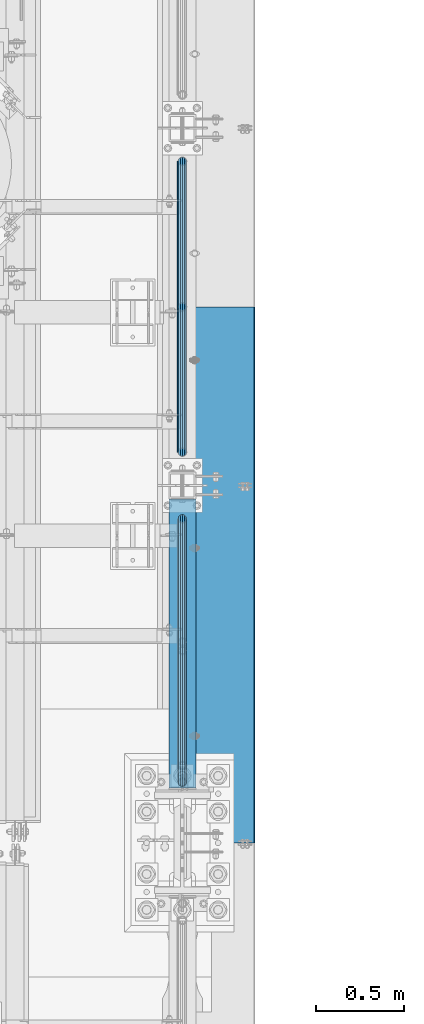
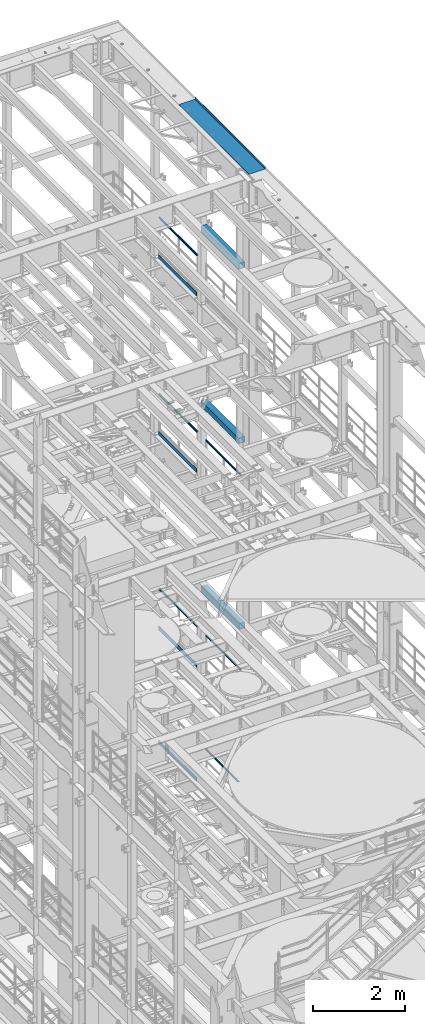
# One storey, part 1077 of 1876: 14 beams, 11 elements without a shape of their own.
"""IFC2X3 building model written with IfcOpenShell, lengths in millimetres."""

from ifc_helpers import new_model, si_unit, frame, origin_with_axes, place, context, subcontext, project, spatial, faceted_brep, material, type_object, element, aggregate, save


model = new_model("IFC2X3")

# Units and contexts
model_context = context("Model", 3, precision=1e-05, world=origin_with_axes())
body_context = subcontext(model_context, "Body", "Model", "MODEL_VIEW")
ifc_project = project(units=[si_unit("LENGTHUNIT", "METRE", prefix="MILLI"), si_unit("AREAUNIT", "SQUARE_METRE"), si_unit("VOLUMEUNIT", "CUBIC_METRE"), si_unit("MASSUNIT", "GRAM", prefix="KILO"), si_unit("TIMEUNIT", "SECOND"), si_unit("PLANEANGLEUNIT", "RADIAN"), si_unit("SOLIDANGLEUNIT", "STERADIAN"), si_unit("THERMODYNAMICTEMPERATUREUNIT", "DEGREE_CELSIUS"), si_unit("LUMINOUSINTENSITYUNIT", "LUMEN")], contexts=[model_context])

# Site, building, storey
site_placement = place(None, origin_with_axes())
site = spatial("IfcSite", under=ifc_project, at=site_placement, CompositionType="ELEMENT")
building_placement = place(site_placement, origin_with_axes())
building = spatial("IfcBuilding", under=site, at=building_placement, Name="Undefined", CompositionType="ELEMENT")
storey_placement = place(building_placement, origin_with_axes())
storey = spatial("IfcBuildingStorey", under=building, at=storey_placement, Name="Undefined", CompositionType="ELEMENT", Elevation=0.0)

# Assembly, beam
assembly_1_placement = place(storey_placement, origin_with_axes())
assembly_1 = element("IfcElementAssembly", 1, at=assembly_1_placement, inside=storey, Name="RAIL", AssemblyPlace="NOTDEFINED", PredefinedType="RIGID_FRAME")
ifc_material_1 = material()
beam_type_1 = type_object("IfcBeamType", Name="PIPE1-1/2SCH40", PredefinedType="NOTDEFINED")
beam_1_placement = place(assembly_1_placement, frame((7620.0, 9817.1, 19059.525), z_axis=(0.0, 0.0, -1.0), x_axis=(0.0, 1.0, 0.0)))
beam_1 = element("IfcBeam", 2, at=beam_1_placement, type_object=beam_type_1, material=ifc_material_1, Name="RAIL", ObjectType="PIPE1-1/2SCH40", context=body_context, shape_type="Brep", body=[
    faceted_brep([(24.1300000000001, -20.4469999999999, 0.0), (34.3535000000002, -17.7076214311803, 10.2235000000001), (1667.4465, -17.7076214311801, 10.2235000000001), (1677.67, -20.4470000000001, 0.0), (41.8376214311802, -10.2235000000001, 17.7076214311819), (1659.96237856882, -10.2235000000001, 17.7076214311819), (44.5770000000002, 0.0, 20.4470000000001), (1657.223, 0.0, 20.4470000000001), (41.8376214311802, 10.2235000000001, 17.7076214311819), (1659.96237856882, 10.2235000000001, 17.7076214311819), (34.3535000000002, 17.7076214311803, 10.2235000000001), (1667.4465, 17.7076214311801, 10.2235000000001), (24.1300000000001, 20.4469999999999, 0.0), (1677.67, 20.4470000000001, 0.0), (13.9065000000001, 17.7076214311803, -10.2235000000001), (1687.8935, 17.7076214311801, -10.2235000000001), (6.42237856882002, 10.2235000000001, -17.7076214311819), (1695.37762143118, 10.2235000000001, -17.7076214311819), (3.68299999999999, 0.0, -20.4470000000001), (1698.117, 0.0, -20.4470000000001), (6.42237856882002, -10.2235000000001, -17.7076214311819), (1695.37762143118, -10.2235000000001, -17.7076214311819), (13.9065000000001, -17.7076214311803, -10.2235000000001), (1687.8935, -17.7076214311801, -10.2235000000001), (24.1299999999854, -24.1299999999992, 0.0), (12.0650000000064, -20.8971929933177, -12.0649999999987), (1689.735, -20.8971929933186, -12.0649999999987), (1677.67, -24.1300000000001, 0.0), (3.23280700668147, -12.0650000000001, -20.8971929933177), (1698.56719299332, -12.0649999999996, -20.8971929933177), (-1.45519152283669e-11, 0.0, -24.130000000001), (1701.8, 0.0, -24.130000000001), (3.23280700668147, 12.0650000000001, -20.8971929933177), (1698.56719299332, 12.0649999999996, -20.8971929933177), (12.0650000000064, 20.8971929933177, -12.0649999999987), (1689.735, 20.8971929933186, -12.0649999999987), (24.1300000000047, 24.1299999999992, 0.0), (1677.67, 24.1300000000001, 0.0), (36.1949999999997, 20.8971929933184, 12.0649999999987), (1665.605, 20.8971929933186, 12.0649999999987), (45.0271929933187, 12.0650000000001, 20.8971929933177), (1656.77280700668, 12.0649999999996, 20.8971929933177), (48.2600000000002, 0.0, 24.130000000001), (1653.54, 0.0, 24.130000000001), (45.0271929933187, -12.0650000000001, 20.8971929933177), (1656.77280700668, -12.0649999999996, 20.8971929933177), (36.1949999999997, -20.8971929933184, 12.0649999999987), (1665.605, -20.8971929933186, 12.0649999999987)], [[[0, 1, 2, 3]], [[1, 4, 5, 2]], [[4, 6, 7, 5]], [[6, 8, 9, 7]], [[8, 10, 11, 9]], [[10, 12, 13, 11]], [[12, 14, 15, 13]], [[14, 16, 17, 15]], [[16, 18, 19, 17]], [[18, 20, 21, 19]], [[20, 22, 23, 21]], [[22, 0, 3, 23]], [[24, 25, 26, 27]], [[25, 28, 29, 26]], [[28, 30, 31, 29]], [[30, 32, 33, 31]], [[32, 34, 35, 33]], [[34, 36, 37, 35]], [[36, 38, 39, 37]], [[38, 40, 41, 39]], [[40, 42, 43, 41]], [[42, 44, 45, 43]], [[44, 46, 47, 45]], [[46, 24, 27, 47]], [[29, 31, 33, 35, 37, 39, 41, 43, 45, 47, 27, 26], [5, 7, 9, 11, 13, 15, 17, 19, 21, 23, 3, 2]], [[46, 44, 42, 40, 38, 36, 34, 32, 30, 28, 25, 24], [22, 20, 18, 16, 14, 12, 10, 8, 6, 4, 1, 0]]]),
])

assembly_2_placement = place(storey_placement, origin_with_axes())
assembly_2 = element("IfcElementAssembly", 3, at=assembly_2_placement, inside=storey, Name="RAIL", AssemblyPlace="NOTDEFINED", PredefinedType="RIGID_FRAME")
beam_2_placement = place(assembly_2_placement, frame((7620.0, 7940.675, 14385.925), z_axis=(0.0, 0.0, -1.0), x_axis=(0.0, 1.0, 0.0)))
beam_2 = element("IfcBeam", 4, at=beam_2_placement, type_object=beam_type_1, material=ifc_material_1, Name="RAIL", ObjectType="PIPE1-1/2SCH40", context=body_context, shape_type="Brep", body=[
    faceted_brep([(24.1300000000001, -20.4469999999999, 0.0), (34.3535000000002, -17.7076214311803, 10.2235000000001), (1511.8715, -17.7076214311801, 10.2235000000001), (1522.095, -20.4470000000001, 0.0), (41.8376214311802, -10.2235000000001, 17.7076214311819), (1504.38737856882, -10.2235000000001, 17.7076214311819), (44.5770000000002, 0.0, 20.4470000000001), (1501.648, 0.0, 20.4470000000001), (41.8376214311802, 10.2235000000001, 17.7076214311819), (1504.38737856882, 10.2235000000001, 17.7076214311819), (34.3535000000002, 17.7076214311803, 10.2235000000001), (1511.8715, 17.7076214311801, 10.2235000000001), (24.1300000000001, 20.4469999999999, 0.0), (1522.095, 20.4470000000001, 0.0), (13.9065000000001, 17.7076214311803, -10.2235000000001), (1532.3185, 17.7076214311801, -10.2235000000001), (6.42237856882002, 10.2235000000001, -17.7076214311819), (1539.80262143118, 10.2235000000001, -17.7076214311819), (3.68299999999999, 0.0, -20.4470000000001), (1542.542, 0.0, -20.4470000000001), (6.42237856882002, -10.2235000000001, -17.7076214311819), (1539.80262143118, -10.2235000000001, -17.7076214311819), (13.9065000000001, -17.7076214311803, -10.2235000000001), (1532.3185, -17.7076214311801, -10.2235000000001), (24.1299999999854, -24.1299999999992, 0.0), (12.0650000000064, -20.8971929933177, -12.0649999999987), (1534.16, -20.8971929933186, -12.0649999999987), (1522.095, -24.1300000000001, 0.0), (3.23280700668147, -12.0650000000001, -20.8971929933177), (1542.99219299332, -12.0649999999996, -20.8971929933177), (-1.45519152283669e-11, 0.0, -24.130000000001), (1546.225, 0.0, -24.130000000001), (3.23280700668147, 12.0650000000001, -20.8971929933177), (1542.99219299332, 12.0649999999996, -20.8971929933177), (12.0650000000064, 20.8971929933177, -12.0649999999987), (1534.16, 20.8971929933186, -12.0649999999987), (24.1300000000047, 24.1299999999992, 0.0), (1522.095, 24.1300000000001, 0.0), (36.1949999999997, 20.8971929933184, 12.0649999999987), (1510.03, 20.8971929933186, 12.0649999999987), (45.0271929933187, 12.0650000000001, 20.8971929933177), (1501.19780700668, 12.0649999999996, 20.8971929933177), (48.2600000000002, 0.0, 24.130000000001), (1497.965, 0.0, 24.130000000001), (45.0271929933187, -12.0650000000001, 20.8971929933177), (1501.19780700668, -12.0649999999996, 20.8971929933177), (36.1949999999997, -20.8971929933184, 12.0649999999987), (1510.03, -20.8971929933186, 12.0649999999987)], [[[0, 1, 2, 3]], [[1, 4, 5, 2]], [[4, 6, 7, 5]], [[6, 8, 9, 7]], [[8, 10, 11, 9]], [[10, 12, 13, 11]], [[12, 14, 15, 13]], [[14, 16, 17, 15]], [[16, 18, 19, 17]], [[18, 20, 21, 19]], [[20, 22, 23, 21]], [[22, 0, 3, 23]], [[24, 25, 26, 27]], [[25, 28, 29, 26]], [[28, 30, 31, 29]], [[30, 32, 33, 31]], [[32, 34, 35, 33]], [[34, 36, 37, 35]], [[36, 38, 39, 37]], [[38, 40, 41, 39]], [[40, 42, 43, 41]], [[42, 44, 45, 43]], [[44, 46, 47, 45]], [[46, 24, 27, 47]], [[29, 31, 33, 35, 37, 39, 41, 43, 45, 47, 27, 26], [5, 7, 9, 11, 13, 15, 17, 19, 21, 23, 3, 2]], [[46, 44, 42, 40, 38, 36, 34, 32, 30, 28, 25, 24], [22, 20, 18, 16, 14, 12, 10, 8, 6, 4, 1, 0]]]),
])
aggregate(assembly_2, [beam_2])

assembly_3_placement = place(storey_placement, origin_with_axes())
assembly_3 = element("IfcElementAssembly", 5, at=assembly_3_placement, inside=storey, Name="RAIL", AssemblyPlace="NOTDEFINED", PredefinedType="RIGID_FRAME")
beam_3_placement = place(assembly_3_placement, frame((7620.0, 9817.1, 14385.925), z_axis=(0.0, 0.0, -1.0), x_axis=(0.0, 1.0, 0.0)))
beam_3 = element("IfcBeam", 6, at=beam_3_placement, type_object=beam_type_1, material=ifc_material_1, Name="RAIL", ObjectType="PIPE1-1/2SCH40", context=body_context, shape_type="Brep", body=[
    faceted_brep([(24.1300000000001, -20.4469999999999, 0.0), (34.3535000000002, -17.7076214311803, 10.2235000000001), (1667.4465, -17.7076214311801, 10.2235000000001), (1677.67, -20.4470000000001, 0.0), (41.8376214311802, -10.2235000000001, 17.7076214311819), (1659.96237856882, -10.2235000000001, 17.7076214311819), (44.5770000000002, 0.0, 20.4470000000001), (1657.223, 0.0, 20.4470000000001), (41.8376214311802, 10.2235000000001, 17.7076214311819), (1659.96237856882, 10.2235000000001, 17.7076214311819), (34.3535000000002, 17.7076214311803, 10.2235000000001), (1667.4465, 17.7076214311801, 10.2235000000001), (24.1300000000001, 20.4469999999999, 0.0), (1677.67, 20.4470000000001, 0.0), (13.9065000000001, 17.7076214311803, -10.2235000000001), (1687.8935, 17.7076214311801, -10.2235000000001), (6.42237856882002, 10.2235000000001, -17.7076214311819), (1695.37762143118, 10.2235000000001, -17.7076214311819), (3.68299999999999, 0.0, -20.4470000000001), (1698.117, 0.0, -20.4470000000001), (6.42237856882002, -10.2235000000001, -17.7076214311819), (1695.37762143118, -10.2235000000001, -17.7076214311819), (13.9065000000001, -17.7076214311803, -10.2235000000001), (1687.8935, -17.7076214311801, -10.2235000000001), (24.1299999999854, -24.1299999999992, 0.0), (12.0650000000064, -20.8971929933177, -12.0649999999987), (1689.735, -20.8971929933186, -12.0649999999987), (1677.67, -24.1300000000001, 0.0), (3.23280700668147, -12.0650000000001, -20.8971929933177), (1698.56719299332, -12.0649999999996, -20.8971929933177), (-1.45519152283669e-11, 0.0, -24.130000000001), (1701.8, 0.0, -24.130000000001), (3.23280700668147, 12.0650000000001, -20.8971929933177), (1698.56719299332, 12.0649999999996, -20.8971929933177), (12.0650000000064, 20.8971929933177, -12.0649999999987), (1689.735, 20.8971929933186, -12.0649999999987), (24.1300000000047, 24.1299999999992, 0.0), (1677.67, 24.1300000000001, 0.0), (36.1949999999997, 20.8971929933184, 12.0649999999987), (1665.605, 20.8971929933186, 12.0649999999987), (45.0271929933187, 12.0650000000001, 20.8971929933177), (1656.77280700668, 12.0649999999996, 20.8971929933177), (48.2600000000002, 0.0, 24.130000000001), (1653.54, 0.0, 24.130000000001), (45.0271929933187, -12.0650000000001, 20.8971929933177), (1656.77280700668, -12.0649999999996, 20.8971929933177), (36.1949999999997, -20.8971929933184, 12.0649999999987), (1665.605, -20.8971929933186, 12.0649999999987)], [[[0, 1, 2, 3]], [[1, 4, 5, 2]], [[4, 6, 7, 5]], [[6, 8, 9, 7]], [[8, 10, 11, 9]], [[10, 12, 13, 11]], [[12, 14, 15, 13]], [[14, 16, 17, 15]], [[16, 18, 19, 17]], [[18, 20, 21, 19]], [[20, 22, 23, 21]], [[22, 0, 3, 23]], [[24, 25, 26, 27]], [[25, 28, 29, 26]], [[28, 30, 31, 29]], [[30, 32, 33, 31]], [[32, 34, 35, 33]], [[34, 36, 37, 35]], [[36, 38, 39, 37]], [[38, 40, 41, 39]], [[40, 42, 43, 41]], [[42, 44, 45, 43]], [[44, 46, 47, 45]], [[46, 24, 27, 47]], [[29, 31, 33, 35, 37, 39, 41, 43, 45, 47, 27, 26], [5, 7, 9, 11, 13, 15, 17, 19, 21, 23, 3, 2]], [[46, 44, 42, 40, 38, 36, 34, 32, 30, 28, 25, 24], [22, 20, 18, 16, 14, 12, 10, 8, 6, 4, 1, 0]]]),
])

assembly_4_placement = place(storey_placement, origin_with_axes())
assembly_4 = element("IfcElementAssembly", 7, at=assembly_4_placement, inside=storey, Name="RAIL", AssemblyPlace="NOTDEFINED", PredefinedType="RIGID_FRAME")
beam_4_placement = place(assembly_4_placement, frame((7620.0, 7940.675, 9229.725), z_axis=(0.0, 0.0, -1.0), x_axis=(0.0, 1.0, 0.0)))
beam_4 = element("IfcBeam", 8, at=beam_4_placement, type_object=beam_type_1, material=ifc_material_1, Name="RAIL", ObjectType="PIPE1-1/2SCH40", context=body_context, shape_type="Brep", body=[
    faceted_brep([(24.1300000000001, -20.4469999999999, 0.0), (34.3535000000002, -17.7076214311803, 10.2235000000001), (1511.8715, -17.7076214311801, 10.2235000000001), (1522.095, -20.4470000000001, 0.0), (41.8376214311802, -10.2235000000001, 17.7076214311819), (1504.38737856882, -10.2235000000001, 17.7076214311819), (44.5770000000002, 0.0, 20.4470000000001), (1501.648, 0.0, 20.4470000000001), (41.8376214311802, 10.2235000000001, 17.7076214311819), (1504.38737856882, 10.2235000000001, 17.7076214311819), (34.3535000000002, 17.7076214311803, 10.2235000000001), (1511.8715, 17.7076214311801, 10.2235000000001), (24.1300000000001, 20.4469999999999, 0.0), (1522.095, 20.4470000000001, 0.0), (13.9065000000001, 17.7076214311803, -10.2235000000001), (1532.3185, 17.7076214311801, -10.2235000000001), (6.42237856882002, 10.2235000000001, -17.7076214311819), (1539.80262143118, 10.2235000000001, -17.7076214311819), (3.68299999999999, 0.0, -20.4470000000001), (1542.542, 0.0, -20.4470000000001), (6.42237856882002, -10.2235000000001, -17.7076214311819), (1539.80262143118, -10.2235000000001, -17.7076214311819), (13.9065000000001, -17.7076214311803, -10.2235000000001), (1532.3185, -17.7076214311801, -10.2235000000001), (24.1299999999854, -24.1299999999992, 0.0), (12.0650000000064, -20.8971929933177, -12.0649999999987), (1534.16, -20.8971929933186, -12.0649999999987), (1522.095, -24.1300000000001, 0.0), (3.23280700668147, -12.0650000000001, -20.8971929933177), (1542.99219299332, -12.0649999999996, -20.8971929933177), (-1.45519152283669e-11, 0.0, -24.130000000001), (1546.225, 0.0, -24.130000000001), (3.23280700668147, 12.0650000000001, -20.8971929933177), (1542.99219299332, 12.0649999999996, -20.8971929933177), (12.0650000000064, 20.8971929933177, -12.0649999999987), (1534.16, 20.8971929933186, -12.0649999999987), (24.1300000000047, 24.1299999999992, 0.0), (1522.095, 24.1300000000001, 0.0), (36.1949999999997, 20.8971929933184, 12.0649999999987), (1510.03, 20.8971929933186, 12.0649999999987), (45.0271929933187, 12.0650000000001, 20.8971929933177), (1501.19780700668, 12.0649999999996, 20.8971929933177), (48.2600000000002, 0.0, 24.130000000001), (1497.965, 0.0, 24.130000000001), (45.0271929933187, -12.0650000000001, 20.8971929933177), (1501.19780700668, -12.0649999999996, 20.8971929933177), (36.1949999999997, -20.8971929933184, 12.0649999999987), (1510.03, -20.8971929933186, 12.0649999999987)], [[[0, 1, 2, 3]], [[1, 4, 5, 2]], [[4, 6, 7, 5]], [[6, 8, 9, 7]], [[8, 10, 11, 9]], [[10, 12, 13, 11]], [[12, 14, 15, 13]], [[14, 16, 17, 15]], [[16, 18, 19, 17]], [[18, 20, 21, 19]], [[20, 22, 23, 21]], [[22, 0, 3, 23]], [[24, 25, 26, 27]], [[25, 28, 29, 26]], [[28, 30, 31, 29]], [[30, 32, 33, 31]], [[32, 34, 35, 33]], [[34, 36, 37, 35]], [[36, 38, 39, 37]], [[38, 40, 41, 39]], [[40, 42, 43, 41]], [[42, 44, 45, 43]], [[44, 46, 47, 45]], [[46, 24, 27, 47]], [[29, 31, 33, 35, 37, 39, 41, 43, 45, 47, 27, 26], [5, 7, 9, 11, 13, 15, 17, 19, 21, 23, 3, 2]], [[46, 44, 42, 40, 38, 36, 34, 32, 30, 28, 25, 24], [22, 20, 18, 16, 14, 12, 10, 8, 6, 4, 1, 0]]]),
])
aggregate(assembly_4, [beam_4])

assembly_5_placement = place(storey_placement, origin_with_axes())
assembly_5 = element("IfcElementAssembly", 9, at=assembly_5_placement, inside=storey, Name="RAIL", AssemblyPlace="NOTDEFINED", PredefinedType="RIGID_FRAME")
beam_5_placement = place(assembly_5_placement, frame((7620.0, 9817.1, 9229.725), z_axis=(0.0, 0.0, -1.0), x_axis=(0.0, 1.0, 0.0)))
beam_5 = element("IfcBeam", 10, at=beam_5_placement, type_object=beam_type_1, material=ifc_material_1, Name="RAIL", ObjectType="PIPE1-1/2SCH40", context=body_context, shape_type="Brep", body=[
    faceted_brep([(24.1300000000001, -20.4469999999999, 0.0), (34.3535000000002, -17.7076214311803, 10.2235000000001), (1667.4465, -17.7076214311801, 10.2235000000001), (1677.67, -20.4470000000001, 0.0), (41.8376214311802, -10.2235000000001, 17.7076214311819), (1659.96237856882, -10.2235000000001, 17.7076214311819), (44.5770000000002, 0.0, 20.4470000000001), (1657.223, 0.0, 20.4470000000001), (41.8376214311802, 10.2235000000001, 17.7076214311819), (1659.96237856882, 10.2235000000001, 17.7076214311819), (34.3535000000002, 17.7076214311803, 10.2235000000001), (1667.4465, 17.7076214311801, 10.2235000000001), (24.1300000000001, 20.4469999999999, 0.0), (1677.67, 20.4470000000001, 0.0), (13.9065000000001, 17.7076214311803, -10.2235000000001), (1687.8935, 17.7076214311801, -10.2235000000001), (6.42237856882002, 10.2235000000001, -17.7076214311819), (1695.37762143118, 10.2235000000001, -17.7076214311819), (3.68299999999999, 0.0, -20.4470000000001), (1698.117, 0.0, -20.4470000000001), (6.42237856882002, -10.2235000000001, -17.7076214311819), (1695.37762143118, -10.2235000000001, -17.7076214311819), (13.9065000000001, -17.7076214311803, -10.2235000000001), (1687.8935, -17.7076214311801, -10.2235000000001), (24.1299999999854, -24.1299999999992, 0.0), (12.0650000000064, -20.8971929933177, -12.0649999999987), (1689.735, -20.8971929933186, -12.0649999999987), (1677.67, -24.1300000000001, 0.0), (3.23280700668147, -12.0650000000001, -20.8971929933177), (1698.56719299332, -12.0649999999996, -20.8971929933177), (-1.45519152283669e-11, 0.0, -24.130000000001), (1701.8, 0.0, -24.130000000001), (3.23280700668147, 12.0650000000001, -20.8971929933177), (1698.56719299332, 12.0649999999996, -20.8971929933177), (12.0650000000064, 20.8971929933177, -12.0649999999987), (1689.735, 20.8971929933186, -12.0649999999987), (24.1300000000047, 24.1299999999992, 0.0), (1677.67, 24.1300000000001, 0.0), (36.1949999999997, 20.8971929933184, 12.0649999999987), (1665.605, 20.8971929933186, 12.0649999999987), (45.0271929933187, 12.0650000000001, 20.8971929933177), (1656.77280700668, 12.0649999999996, 20.8971929933177), (48.2600000000002, 0.0, 24.130000000001), (1653.54, 0.0, 24.130000000001), (45.0271929933187, -12.0650000000001, 20.8971929933177), (1656.77280700668, -12.0649999999996, 20.8971929933177), (36.1949999999997, -20.8971929933184, 12.0649999999987), (1665.605, -20.8971929933186, 12.0649999999987)], [[[0, 1, 2, 3]], [[1, 4, 5, 2]], [[4, 6, 7, 5]], [[6, 8, 9, 7]], [[8, 10, 11, 9]], [[10, 12, 13, 11]], [[12, 14, 15, 13]], [[14, 16, 17, 15]], [[16, 18, 19, 17]], [[18, 20, 21, 19]], [[20, 22, 23, 21]], [[22, 0, 3, 23]], [[24, 25, 26, 27]], [[25, 28, 29, 26]], [[28, 30, 31, 29]], [[30, 32, 33, 31]], [[32, 34, 35, 33]], [[34, 36, 37, 35]], [[36, 38, 39, 37]], [[38, 40, 41, 39]], [[40, 42, 43, 41]], [[42, 44, 45, 43]], [[44, 46, 47, 45]], [[46, 24, 27, 47]], [[29, 31, 33, 35, 37, 39, 41, 43, 45, 47, 27, 26], [5, 7, 9, 11, 13, 15, 17, 19, 21, 23, 3, 2]], [[46, 44, 42, 40, 38, 36, 34, 32, 30, 28, 25, 24], [22, 20, 18, 16, 14, 12, 10, 8, 6, 4, 1, 0]]]),
])

assembly_6_placement = place(storey_placement, origin_with_axes())
assembly_6 = element("IfcElementAssembly", 11, at=assembly_6_placement, inside=storey, Name="RAIL", AssemblyPlace="NOTDEFINED", PredefinedType="RIGID_FRAME")
beam_6_placement = place(assembly_6_placement, frame((7620.0, 8035.925, 6207.125), z_axis=(0.0, 0.0, -1.0), x_axis=(0.0, 1.0, 0.0)))
beam_6 = element("IfcBeam", 12, at=beam_6_placement, type_object=beam_type_1, material=ifc_material_1, Name="RAIL", ObjectType="PIPE1-1/2SCH40", context=body_context, shape_type="Brep", body=[
    faceted_brep([(24.1300000000001, -20.4469999999999, 0.0), (34.3535000000002, -17.7076214311803, 10.2235000000001), (1416.6215, -17.7076214311801, 10.2235000000001), (1426.845, -20.4470000000001, 0.0), (41.8376214311802, -10.2235000000001, 17.7076214311819), (1409.13737856882, -10.2235000000001, 17.7076214311801), (44.5770000000002, 0.0, 20.4470000000001), (1406.398, 0.0, 20.4470000000001), (41.8376214311802, 10.2235000000001, 17.7076214311819), (1409.13737856882, 10.2235000000001, 17.7076214311801), (34.3535000000002, 17.7076214311803, 10.2235000000001), (1416.6215, 17.7076214311801, 10.2235000000001), (24.1300000000001, 20.4469999999999, 0.0), (1426.845, 20.4470000000001, 0.0), (13.9065000000001, 17.7076214311803, -10.2235000000001), (1437.0685, 17.7076214311801, -10.2235000000001), (6.42237856882002, 10.2235000000001, -17.7076214311819), (1444.55262143118, 10.2235000000001, -17.7076214311801), (3.68299999999999, 0.0, -20.4470000000001), (1447.292, 0.0, -20.4470000000001), (6.42237856882002, -10.2235000000001, -17.7076214311819), (1444.55262143118, -10.2235000000001, -17.7076214311801), (13.9065000000001, -17.7076214311803, -10.2235000000001), (1437.0685, -17.7076214311801, -10.2235000000001), (24.1299999999854, -24.1299999999992, 0.0), (12.0650000000064, -20.8971929933177, -12.0649999999987), (1438.91, -20.8971929933186, -12.0649999999996), (1426.845, -24.1300000000001, 0.0), (3.23280700668147, -12.0650000000001, -20.8971929933177), (1447.74219299332, -12.0649999999996, -20.8971929933186), (-1.45519152283669e-11, 0.0, -24.130000000001), (1450.975, 0.0, -24.1300000000001), (3.23280700668147, 12.0650000000001, -20.8971929933177), (1447.74219299332, 12.0649999999996, -20.8971929933186), (12.0650000000064, 20.8971929933177, -12.0649999999987), (1438.91, 20.8971929933186, -12.0649999999996), (24.1300000000047, 24.1299999999992, 0.0), (1426.845, 24.1300000000001, 0.0), (36.1949999999997, 20.8971929933184, 12.0649999999987), (1414.78, 20.8971929933186, 12.0649999999996), (45.0271929933187, 12.0650000000001, 20.8971929933177), (1405.94780700668, 12.0649999999996, 20.8971929933186), (48.2600000000002, 0.0, 24.130000000001), (1402.715, 0.0, 24.1300000000001), (45.0271929933187, -12.0650000000001, 20.8971929933177), (1405.94780700668, -12.0649999999996, 20.8971929933186), (36.1949999999997, -20.8971929933184, 12.0649999999987), (1414.78, -20.8971929933186, 12.0649999999996)], [[[0, 1, 2, 3]], [[1, 4, 5, 2]], [[4, 6, 7, 5]], [[6, 8, 9, 7]], [[8, 10, 11, 9]], [[10, 12, 13, 11]], [[12, 14, 15, 13]], [[14, 16, 17, 15]], [[16, 18, 19, 17]], [[18, 20, 21, 19]], [[20, 22, 23, 21]], [[22, 0, 3, 23]], [[24, 25, 26, 27]], [[25, 28, 29, 26]], [[28, 30, 31, 29]], [[30, 32, 33, 31]], [[32, 34, 35, 33]], [[34, 36, 37, 35]], [[36, 38, 39, 37]], [[38, 40, 41, 39]], [[40, 42, 43, 41]], [[42, 44, 45, 43]], [[44, 46, 47, 45]], [[46, 24, 27, 47]], [[29, 31, 33, 35, 37, 39, 41, 43, 45, 47, 27, 26], [5, 7, 9, 11, 13, 15, 17, 19, 21, 23, 3, 2]], [[46, 44, 42, 40, 38, 36, 34, 32, 30, 28, 25, 24], [22, 20, 18, 16, 14, 12, 10, 8, 6, 4, 1, 0]]]),
])
aggregate(assembly_6, [beam_6])

assembly_7_placement = place(storey_placement, origin_with_axes())
assembly_7 = element("IfcElementAssembly", 13, at=assembly_7_placement, inside=storey, Name="BEAM", AssemblyPlace="NOTDEFINED", PredefinedType="RIGID_FRAME")
ifc_material_2 = material()
beam_type_2 = type_object("IfcBeamType", Name="HSS6X6X3/8", PredefinedType="NOTDEFINED")
beam_7_placement = place(assembly_7_placement, frame((7620.0, 7908.925, 19958.05), z_axis=(-1.0, 0.0, 0.0), x_axis=(0.0, 1.0, 0.0)))
beam_7 = element("IfcBeam", 14, at=beam_7_placement, type_object=beam_type_2, material=ifc_material_2, Name="BEAM", ObjectType="HSS6X6X3/8", context=body_context, shape_type="Brep", body=[
    faceted_brep([(22.2249999999995, 66.6749999999993, -66.675), (22.2249999999995, -66.6749999999993, -66.675), (1666.875, -66.6749999999993, -66.675), (1666.875, 66.6749999999993, -66.675), (22.2249999999995, -66.6749999999993, 66.675), (1666.875, -66.6749999999993, 66.675), (22.2249999999995, 66.6749999999993, 66.675), (1666.875, 66.6749999999993, 66.675), (22.2249999999995, 76.2000000000007, -76.2), (22.2249999999995, 76.2000000000007, 76.2), (1666.875, 76.2000000000007, 76.2), (1666.875, 76.2000000000007, -76.2), (22.2249999999995, -76.2000000000007, 76.2), (1666.875, -76.2000000000007, 76.2), (22.2249999999995, -76.2000000000007, -76.2), (1666.875, -76.2000000000007, -76.2)], [[[0, 1, 2, 3]], [[1, 4, 5, 2]], [[4, 6, 7, 5]], [[6, 0, 3, 7]], [[8, 9, 10, 11]], [[9, 12, 13, 10]], [[12, 14, 15, 13]], [[14, 8, 11, 15]], [[13, 15, 11, 10], [5, 7, 3, 2]], [[14, 12, 9, 8], [6, 4, 1, 0]]]),
])
aggregate(assembly_7, [beam_7])

assembly_8_placement = place(storey_placement, origin_with_axes())
assembly_8 = element("IfcElementAssembly", 15, at=assembly_8_placement, inside=storey, Name="BEAM", AssemblyPlace="NOTDEFINED", PredefinedType="RIGID_FRAME")
beam_8_placement = place(assembly_8_placement, frame((7620.0, 7908.925, 15335.25), z_axis=(-1.0, 0.0, 0.0), x_axis=(0.0, 1.0, 0.0)))
beam_8 = element("IfcBeam", 16, at=beam_8_placement, type_object=beam_type_2, material=ifc_material_2, Name="BEAM", ObjectType="HSS6X6X3/8", context=body_context, shape_type="Brep", body=[
    faceted_brep([(22.2249999999995, 66.6749999999993, -66.675), (22.2249999999995, -66.6749999999993, -66.675), (1666.875, -66.6749999999993, -66.675), (1666.875, 66.6749999999993, -66.675), (22.2249999999995, -66.6749999999993, 66.675), (1666.875, -66.6749999999993, 66.675), (22.2249999999995, 66.6749999999993, 66.675), (1666.875, 66.6749999999993, 66.675), (22.2249999999995, 76.2000000000007, -76.2), (22.2249999999995, 76.2000000000007, 76.2), (1666.875, 76.2000000000007, 76.2), (1666.875, 76.2000000000007, -76.2), (22.2249999999995, -76.2000000000007, 76.2), (1666.875, -76.2000000000007, 76.2), (22.2249999999995, -76.2000000000007, -76.2), (1666.875, -76.2000000000007, -76.2)], [[[0, 1, 2, 3]], [[1, 4, 5, 2]], [[4, 6, 7, 5]], [[6, 0, 3, 7]], [[8, 9, 10, 11]], [[9, 12, 13, 10]], [[12, 14, 15, 13]], [[14, 8, 11, 15]], [[13, 15, 11, 10], [5, 7, 3, 2]], [[14, 12, 9, 8], [6, 4, 1, 0]]]),
])
aggregate(assembly_8, [beam_8])

assembly_9_placement = place(storey_placement, origin_with_axes())
assembly_9 = element("IfcElementAssembly", 17, at=assembly_9_placement, inside=storey, Name="BEAM", AssemblyPlace="NOTDEFINED", PredefinedType="RIGID_FRAME")
beam_9_placement = place(assembly_9_placement, frame((7620.0, 7908.925, 10420.35), z_axis=(-1.0, 0.0, 0.0), x_axis=(0.0, 1.0, 0.0)))
beam_9 = element("IfcBeam", 18, at=beam_9_placement, type_object=beam_type_2, material=ifc_material_2, Name="BEAM", ObjectType="HSS6X6X3/8", context=body_context, shape_type="Brep", body=[
    faceted_brep([(22.2249999999995, 66.6749999999993, -66.675), (22.2249999999995, -66.6749999999993, -66.675), (1666.875, -66.6749999999993, -66.675), (1666.875, 66.6749999999993, -66.675), (22.2249999999995, -66.6749999999993, 66.675), (1666.875, -66.6749999999993, 66.675), (22.2249999999995, 66.6749999999993, 66.675), (1666.875, 66.6749999999993, 66.675), (22.2249999999995, 76.2000000000007, -76.2), (22.2249999999995, 76.2000000000007, 76.2), (1666.875, 76.2000000000007, 76.2), (1666.875, 76.2000000000007, -76.2), (22.2249999999995, -76.2000000000007, 76.2), (1666.875, -76.2000000000007, 76.2), (22.2249999999995, -76.2000000000007, -76.2), (1666.875, -76.2000000000007, -76.2)], [[[0, 1, 2, 3]], [[1, 4, 5, 2]], [[4, 6, 7, 5]], [[6, 0, 3, 7]], [[8, 9, 10, 11]], [[9, 12, 13, 10]], [[12, 14, 15, 13]], [[14, 8, 11, 15]], [[13, 15, 11, 10], [5, 7, 3, 2]], [[14, 12, 9, 8], [6, 4, 1, 0]]]),
])
aggregate(assembly_9, [beam_9])

# Beam
ifc_material_3 = material(Name="STEEL/A36")
beam_type_3 = type_object("IfcBeamType", PredefinedType="NOTDEFINED")
beam_10_placement = place(assembly_1_placement, frame((7592.69500000001, 9841.23, 18049.875), z_axis=(0.0, 0.0, 1.0), x_axis=(0.0, 1.0, 0.0)))
beam_10 = element("IfcBeam", 19, at=beam_10_placement, type_object=beam_type_3, material=ifc_material_3, Name="PLATE", context=body_context, shape_type="Brep", body=[
    faceted_brep([(0.0, 3.17500000000018, -50.8000000000002), (0.0, 3.17500000000018, 50.8000000000002), (1653.54, 3.175, 50.7999999999993), (1653.54, 3.175, -50.7999999999993), (0.0, -3.17500000000018, 50.8000000000002), (1653.54, -3.175, 50.7999999999993), (0.0, -3.17500000000018, -50.8000000000002), (1653.54, -3.175, -50.7999999999993)], [[[0, 1, 2, 3]], [[1, 4, 5, 2]], [[4, 6, 7, 5]], [[6, 0, 3, 7]], [[5, 7, 3, 2]], [[6, 4, 1, 0]]]),
])

aggregate(assembly_1, [beam_10, beam_1])

beam_11_placement = place(assembly_3_placement, frame((7592.69500000001, 9841.23, 13376.275), z_axis=(0.0, 0.0, 1.0), x_axis=(0.0, 1.0, 0.0)))
beam_11 = element("IfcBeam", 20, at=beam_11_placement, type_object=beam_type_3, material=ifc_material_3, Name="PLATE", context=body_context, shape_type="Brep", body=[
    faceted_brep([(0.0, 3.17500000000018, -50.8000000000002), (0.0, 3.17500000000018, 50.8000000000002), (1653.54, 3.175, 50.7999999999993), (1653.54, 3.175, -50.7999999999993), (0.0, -3.17500000000018, 50.8000000000002), (1653.54, -3.175, 50.7999999999993), (0.0, -3.17500000000018, -50.8000000000002), (1653.54, -3.175, -50.7999999999993)], [[[0, 1, 2, 3]], [[1, 4, 5, 2]], [[4, 6, 7, 5]], [[6, 0, 3, 7]], [[5, 7, 3, 2]], [[6, 4, 1, 0]]]),
])

aggregate(assembly_3, [beam_11, beam_3])

beam_12_placement = place(assembly_5_placement, frame((7592.69500000001, 9841.23, 8220.075), z_axis=(0.0, 0.0, 1.0), x_axis=(0.0, 1.0, 0.0)))
beam_12 = element("IfcBeam", 21, at=beam_12_placement, type_object=beam_type_3, material=ifc_material_3, Name="PLATE", context=body_context, shape_type="Brep", body=[
    faceted_brep([(0.0, 3.17500000000018, -50.8000000000002), (0.0, 3.17500000000018, 50.8000000000002), (1653.54, 3.175, 50.7999999999993), (1653.54, 3.175, -50.7999999999993), (0.0, -3.17500000000018, 50.8000000000002), (1653.54, -3.175, 50.7999999999993), (0.0, -3.17500000000018, -50.8000000000002), (1653.54, -3.175, -50.7999999999993)], [[[0, 1, 2, 3]], [[1, 4, 5, 2]], [[4, 6, 7, 5]], [[6, 0, 3, 7]], [[5, 7, 3, 2]], [[6, 4, 1, 0]]]),
])

aggregate(assembly_5, [beam_12, beam_5])

# Assembly, beam
assembly_10_placement = place(storey_placement, origin_with_axes())
assembly_10 = element("IfcElementAssembly", 22, at=assembly_10_placement, inside=storey, Name="RAIL", AssemblyPlace="NOTDEFINED", PredefinedType="RIGID_FRAME")
beam_13_placement = place(assembly_10_placement, frame((7592.69500000001, 9841.23, 5197.475), z_axis=(0.0, 0.0, 1.0), x_axis=(0.0, 1.0, 0.0)))
beam_13 = element("IfcBeam", 23, at=beam_13_placement, type_object=beam_type_3, material=ifc_material_3, Name="PLATE", context=body_context, shape_type="Brep", body=[
    faceted_brep([(0.0, 3.17500000000018, -50.8000000000002), (0.0, 3.17500000000018, 50.8000000000002), (1653.54, 3.175, 50.7999999999993), (1653.54, 3.175, -50.7999999999993), (0.0, -3.17500000000018, 50.8000000000002), (1653.54, -3.175, 50.7999999999993), (0.0, -3.17500000000018, -50.8000000000002), (1653.54, -3.175, -50.7999999999993)], [[[0, 1, 2, 3]], [[1, 4, 5, 2]], [[4, 6, 7, 5]], [[6, 0, 3, 7]], [[5, 7, 3, 2]], [[6, 4, 1, 0]]]),
])
aggregate(assembly_10, [beam_13])

assembly_11_placement = place(storey_placement, origin_with_axes())
assembly_11 = element("IfcElementAssembly", 24, at=assembly_11_placement, inside=storey, Name="BENT PLATE", AssemblyPlace="NOTDEFINED", PredefinedType="RIGID_FRAME")
beam_type_4 = type_object("IfcBeamType", PredefinedType="NOTDEFINED")
beam_14_placement = place(assembly_11_placement, frame((7619.99998321378, 9144.0, 22558.375), z_axis=(0.0, 1.0, 0.0), x_axis=(0.999999999986024, 0.0, -5.28699999861059e-06)))
beam_14 = element("IfcBeam", 25, at=beam_14_placement, type_object=beam_type_4, material=ifc_material_3, Name="BENT PLATE", context=body_context, shape_type="Brep", body=[
    faceted_brep([(9.877112461254e-10, -3.17499999999563, -1524.0), (9.877112461254e-10, -3.17499999999563, 1524.0), (-9.88620740827173e-10, 3.17500000000291, 1524.0), (-9.88620740827173e-10, 3.17500000000291, -1524.0), (412.74996162189, 3.17499999736538, 1524.0), (412.74996162189, 3.17499999736538, -1524.0), (406.399963385245, -3.17500000258951, -1524.0), (406.399963385245, -3.17500000258951, 1524.0), (412.749980137296, -63.5005721684938, 1524.0), (412.749980137296, -63.5005721684938, -1524.0), (406.399980137296, -63.5005739318367, 1524.0), (406.399980137296, -63.5005739318367, -1524.0)], [[[0, 1, 2, 3]], [[3, 2, 4, 5]], [[1, 0, 6, 7]], [[5, 4, 8, 9]], [[4, 2, 1, 7, 10, 8]], [[7, 6, 11, 10]], [[6, 0, 3, 5, 9, 11]], [[10, 11, 9, 8]]]),
])
aggregate(assembly_11, [beam_14])

save(model, "model.ifc")
